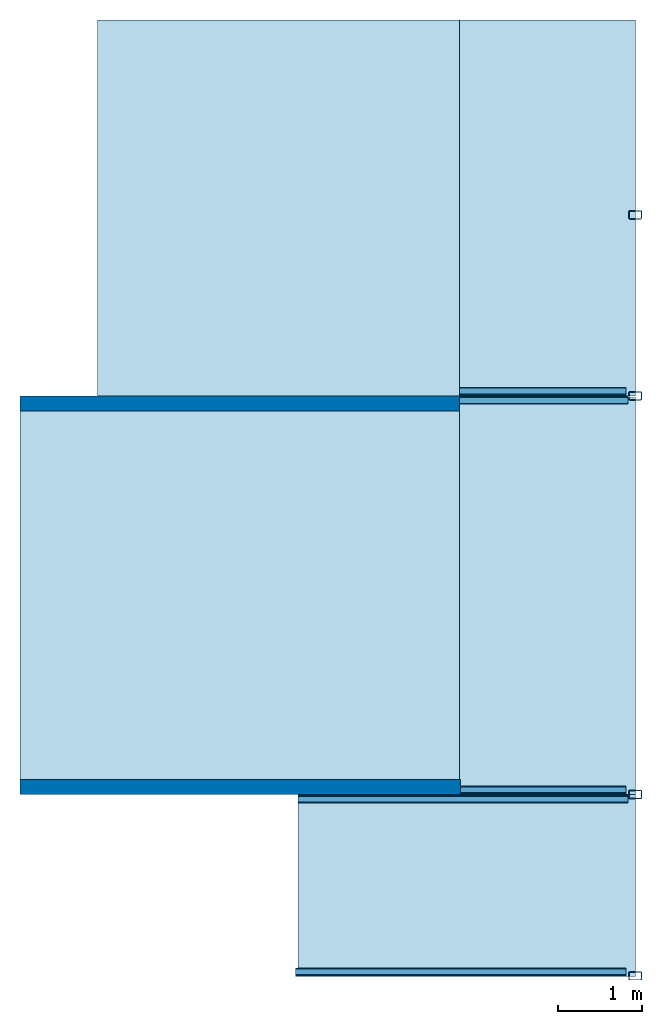
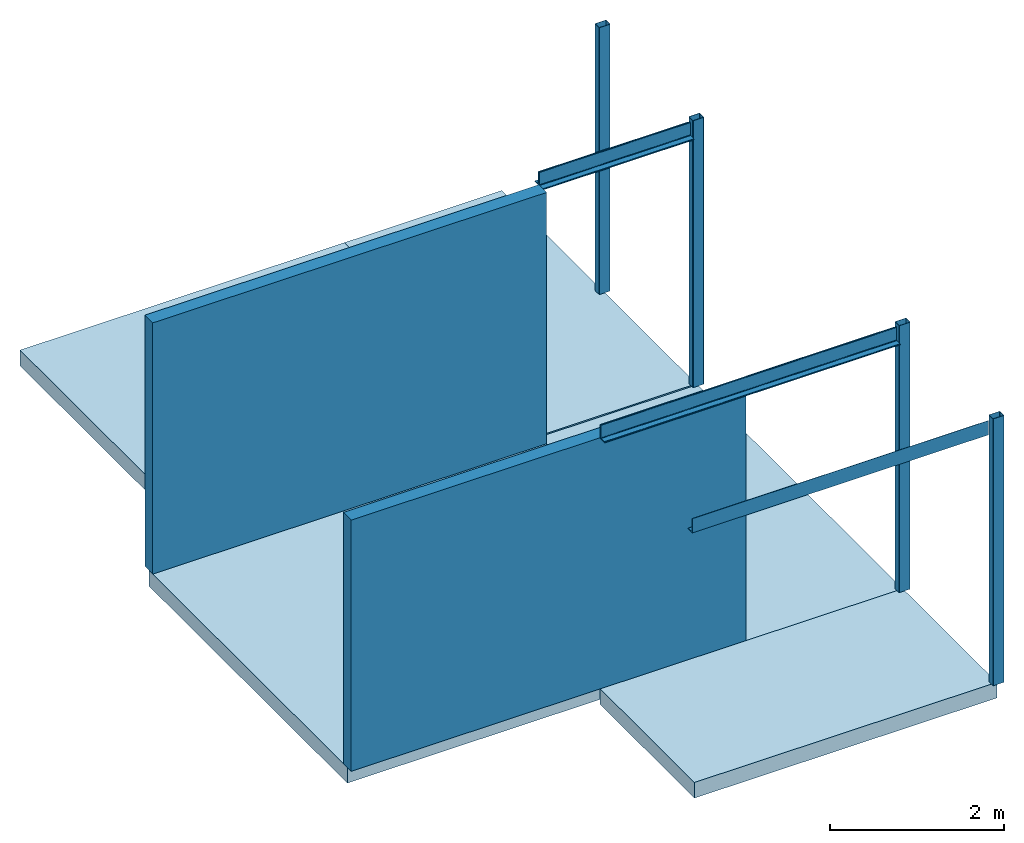
# One storey: 5 beams, 5 slabs, 4 columns, 2 walls.
"""IFC2X3 building model written with IfcOpenShell, lengths in millimetres."""

from ifc_helpers import new_model, entity, si_unit, converted_unit, frame, frame_2d, origin, place, context, project, spatial, polyline, circle_curve, parameter, trimmed, segment, composite_curve, rectangle, outline, extrude, clip, bounded_halfspace, source, transform, mapped, material, layer, layer_set, layer_usage, type_object, type_shapes, element, save


model = new_model("IFC2X3")

# Units and contexts
model_context = context("Model", 3, precision=1e-06, world=origin())
plan_context = context("Plan", 3, precision=1e-06, world=origin())
ifc_project = project(units=[si_unit("LENGTHUNIT", "METRE", prefix="MILLI"), si_unit("AREAUNIT", "SQUARE_METRE", prefix="MILLI"), si_unit("VOLUMEUNIT", "CUBIC_METRE", prefix="MILLI"), converted_unit("PLANEANGLEUNIT", "DEGREE", entity("IfcRatioMeasure", 0.01745329251994328), si_unit("PLANEANGLEUNIT", "RADIAN"), dimensions=[0, 0, 0, 0, 0, 0, 0]), si_unit("TIMEUNIT", "SECOND")], contexts=[model_context, plan_context])

# Site, building, storey
site_placement = place(None, origin())
site = spatial("IfcSite", under=ifc_project, at=site_placement, CompositionType="ELEMENT")
building_placement = place(None, origin())
building = spatial("IfcBuilding", under=site, at=building_placement, CompositionType="ELEMENT")
storey_placement = place(building_placement, frame((0.0, 0.0, 3750.0)))
storey = spatial("IfcBuildingStorey", under=building, at=storey_placement, Name="Level 2", CompositionType="ELEMENT", Elevation=3750.000000000001)

# Columns
ifc_material_1 = material(Name="Metal - Steel - 345 MPa")
column_type = type_object("IfcColumnType", Name="150x100x5", PredefinedType="COLUMN")
shared_shape = source(origin(), model_context, "Body", "SweptSolid", [
    extrude(outline(composite_curve([segment(polyline([(-40.0, -75.0), (40.0, -75.0)]), True, "CONTINUOUS"), segment(trimmed(circle_curve(frame_2d((40.0, -65.0), x_axis=(-1.0, 0.0)), 9.999999999997998), [parameter(90.00000000000009)], [parameter(180.0000000000002)], True, "PARAMETER"), True, "CONTINUOUS"), segment(polyline([(50.0, -65.0), (50.0, 65.0)]), True, "CONTINUOUS"), segment(trimmed(circle_curve(frame_2d((40.0, 65.0), x_axis=(-1.0, 0.0)), 9.99999999999999), [parameter(179.9999999999999)], [parameter(269.9999999999997)], True, "PARAMETER"), True, "CONTINUOUS"), segment(polyline([(40.0, 75.0), (-40.0, 75.0)]), True, "CONTINUOUS"), segment(trimmed(circle_curve(frame_2d((-40.0, 65.0), x_axis=(-1.0, 0.0)), 10.00000000000288), [parameter(269.9999999999995)], [parameter(359.9999999999996)], True, "PARAMETER"), True, "CONTINUOUS"), segment(polyline([(-50.0, 65.0), (-50.0, -65.0)]), True, "CONTINUOUS"), segment(trimmed(circle_curve(frame_2d((-40.0, -65.0), x_axis=(-1.0, 0.0)), 9.999999999996726), [parameter(359.9999999999996)], [parameter(89.99999999999963)], True, "PARAMETER"), True, "CONTINUOUS")], self_intersect=False), holes=[composite_curve([segment(trimmed(circle_curve(frame_2d((-40.0, -65.0), x_axis=(-1.0, 0.0)), 4.999999999996471), [parameter(0.0)], [parameter(89.99999999999999)], True, "PARAMETER"), False, "CONTINUOUS"), segment(polyline([(-45.0, -65.0), (-45.0, 65.0)]), True, "CONTINUOUS"), segment(trimmed(circle_curve(frame_2d((-40.0, 65.0), x_axis=(-1.0, 0.0)), 4.999999999998176), [parameter(270.0)], [parameter(359.9999999999999)], True, "PARAMETER"), False, "CONTINUOUS"), segment(polyline([(-40.0, 70.0), (40.0, 70.0)]), True, "CONTINUOUS"), segment(trimmed(circle_curve(frame_2d((40.0, 65.0), x_axis=(-1.0, 0.0)), 5.000000000001551), [parameter(180.0000000000001)], [parameter(270.0)], True, "PARAMETER"), False, "CONTINUOUS"), segment(polyline([(45.0, 65.0), (45.0, -65.0)]), True, "CONTINUOUS"), segment(trimmed(circle_curve(frame_2d((40.0, -65.0), x_axis=(-1.0, 0.0)), 5.000000000000011), [parameter(90.0000000000005)], [parameter(179.9999999999998)], True, "PARAMETER"), False, "CONTINUOUS"), segment(polyline([(40.0, -70.0), (-40.0, -70.0)]), True, "CONTINUOUS")], self_intersect=False)]), frame((0.0, 0.0, 3750.0), z_axis=(0.0, 0.0, 1.0), x_axis=(-1.0, 0.0, 0.0)), (0.0, 0.0, 1.0), 3749.999999999999),
])
type_shapes(column_type, [shared_shape])
for number, where, z_axis, x_axis in (
    (1, (-11917.18323242557, 151.098768151623, -3750.0), (0.0, 0.0, 1.0), (0.0, 1.0, 0.0)),
    (2, (-11917.18323242557, 2311.098768151621, -3750.0), (0.0, 0.0, 1.0), (0.0, 1.0, 0.0)),
    (3, (-11917.18323242557, 7061.098768151644, -3750.0), (0.0, 0.0, 1.0), (0.0, 1.0, 0.0)),
    (4, (-11917.18323242557, 9217.072263559809, -3750.0), (0.0, 0.0, 1.0), (0.0, 1.0, 0.0)),
):
    element("IfcColumn", number, at=place(storey_placement, frame(where, z_axis=z_axis, x_axis=x_axis)), inside=storey, type_object=column_type, material=ifc_material_1, ObjectType="150x100x5", context=model_context, shape_type="MappedRepresentation", body=[
        mapped(shared_shape, transform((0.0, 0.0, 0.0), scale=1.0)),
    ])

# Beams
beam_1_placement = place(storey_placement, frame((-12017.18323242538, 7061.098768151644, 3750.0), z_axis=(0.0, 0.0, 1.0), x_axis=(0.0, 1.0, 0.0)))
element("IfcBeam", 5, at=beam_1_placement, inside=storey, material=ifc_material_1, ObjectType="L-Angles:CAI200x100x14", context=model_context, shape_type="SweptSolid", body=[
    extrude(outline(composite_curve([segment(polyline([(-34.57142857142937, -63.14285714285688), (65.42857142857281, -63.14285714285688)]), True, "CONTINUOUS"), segment(trimmed(circle_curve(frame_2d((51.42857142857381, -63.14285714285796), x_axis=(1.0, 0.0)), 14.0), [parameter(1.017777498068326e-13)], [parameter(90.00000000000009)], True, "PARAMETER"), True, "CONTINUOUS"), segment(polyline([(51.42857142857381, -49.14285714285788), (-6.571428571429244, -49.14285714285788)]), True, "CONTINUOUS"), segment(trimmed(circle_curve(frame_2d((-6.571428571428161, -35.14285714285782), x_axis=(1.0, 0.0)), 14.0), [parameter(180.0000000000001)], [parameter(269.9999999999999)], True, "PARAMETER"), False, "CONTINUOUS"), segment(polyline([(-20.57142857142823, -35.14285714285782), (-20.57142857142823, 122.8571428571431)]), True, "CONTINUOUS"), segment(trimmed(circle_curve(frame_2d((-34.57142857142829, 122.8571428571431), x_axis=(1.0, 0.0)), 14.0), [parameter(0.0)], [parameter(90.00000000000024)], True, "PARAMETER"), True, "CONTINUOUS"), segment(polyline([(-34.57142857142829, 136.8571428571432), (-34.57142857142937, -63.14285714285688)]), True, "CONTINUOUS")], self_intersect=False)), frame((34.57142857142829, 1994.442034597584, -170.8571428571376), z_axis=(0.0, -1.0, 0.0), x_axis=(1.0, 0.0, 0.0)), (0.0, 0.0, 1.0), 1981.742033987986),
])
beam_2_placement = place(storey_placement, frame((-14011.62526702297, 7061.098768151647, 3750.0), z_axis=(0.0, 0.0, 1.0), x_axis=(0.0, -1.0, 0.0)))
element("IfcBeam", 6, at=beam_2_placement, inside=storey, material=ifc_material_1, ObjectType="L-Angles:CAI200x100x14", context=model_context, shape_type="SweptSolid", body=[
    extrude(outline(composite_curve([segment(polyline([(-63.14285714285488, -34.57142857142903), (136.8571428571451, -34.57142857142903)]), True, "CONTINUOUS"), segment(trimmed(circle_curve(frame_2d((122.8571428571451, -34.57142857142896), x_axis=(0.0, 1.0)), 14.0), [parameter(269.9999999999998)], [parameter(0.0)], True, "PARAMETER"), True, "CONTINUOUS"), segment(polyline([(122.8571428571452, -20.57142857142889), (-35.14285714285575, -20.57142857142804)]), True, "CONTINUOUS"), segment(trimmed(circle_curve(frame_2d((-35.14285714285567, -6.571428571427971), x_axis=(0.0, 1.0)), 14.0), [parameter(90.00000000000009)], [parameter(179.9999999999999)], True, "PARAMETER"), False, "CONTINUOUS"), segment(polyline([(-49.14285714285573, -6.571428571428978), (-49.14285714285541, 51.42857142857407)]), True, "CONTINUOUS"), segment(trimmed(circle_curve(frame_2d((-63.1428571428555, 51.42857142857415), x_axis=(0.0, 1.0)), 14.0), [parameter(269.9999999999999)], [parameter(359.9999999999999)], True, "PARAMETER"), True, "CONTINUOUS"), segment(polyline([(-63.14285714285434, 65.42857142857315), (-63.14285714285488, -34.57142857142903)]), True, "CONTINUOUS")], self_intersect=False)), frame((34.57142857142829, 0.0, -170.8571428571398), z_axis=(0.0, 1.0, 0.0), x_axis=(0.0, 0.0, 1.0)), (0.0, 0.0, 1.0), 2006.742034597402),
])
beam_3_placement = place(storey_placement, frame((-12017.18323242539, 2311.098768151621, 3750.0), z_axis=(0.0, 0.0, 1.0), x_axis=(0.0, 1.0, 0.0)))
element("IfcBeam", 7, at=beam_3_placement, inside=storey, material=ifc_material_1, ObjectType="L-Angles:CAI200x100x14", context=model_context, shape_type="SweptSolid", body=[
    extrude(outline(composite_curve([segment(polyline([(-34.5714285714291, -63.14285714285688), (65.42857142857306, -63.14285714285688)]), True, "CONTINUOUS"), segment(trimmed(circle_curve(frame_2d((51.428571428573, -63.14285714285796), x_axis=(0.0, 1.0)), 14.0), [parameter(269.9999999999999)], [parameter(359.9999999999999)], True, "PARAMETER"), True, "CONTINUOUS"), segment(polyline([(51.428571428573, -49.14285714285788), (-6.571428571428971, -49.14285714285788)]), True, "CONTINUOUS"), segment(trimmed(circle_curve(frame_2d((-6.571428571428971, -35.14285714285782), x_axis=(-1.0, 0.0)), 14.0), [parameter(3.562221243239142e-13)], [parameter(90.00000000000009)], True, "PARAMETER"), False, "CONTINUOUS"), segment(polyline([(-20.57142857142904, -35.14285714285782), (-20.5714285714285, 122.8571428571431)]), True, "CONTINUOUS"), segment(trimmed(circle_curve(frame_2d((-34.57142857142856, 122.8571428571431), x_axis=(0.0, 1.0)), 14.0), [parameter(269.9999999999999)], [parameter(1.52666624710249e-13)], True, "PARAMETER"), True, "CONTINUOUS"), segment(polyline([(-34.57142857142856, 136.8571428571432), (-34.5714285714291, -63.14285714285688)]), True, "CONTINUOUS")], self_intersect=False)), frame((34.57142857142883, 1980.0, -170.8571428571376), z_axis=(0.0, -1.0, 0.0), x_axis=(1.0, 0.0, 0.0)), (0.0, 0.0, 1.0), 1967.299999390401),
])
beam_4_placement = place(storey_placement, frame((-14011.62526702298, 2311.098768151623, 3750.0), z_axis=(0.0, 0.0, 1.0), x_axis=(0.0, -1.0, 0.0)))
element("IfcBeam", 8, at=beam_4_placement, inside=storey, material=ifc_material_1, ObjectType="L-Angles:CAI200x100x14", context=model_context, shape_type="SweptSolid", body=[
    extrude(outline(composite_curve([segment(polyline([(-63.14285714285479, -34.57142857142947), (136.8571428571453, -34.57142857142947)]), True, "CONTINUOUS"), segment(trimmed(circle_curve(frame_2d((122.8571428571452, -34.57142857142944), x_axis=(1.0, 0.0)), 14.0), [parameter(359.9999999999998)], [parameter(90.00000000000009)], True, "PARAMETER"), True, "CONTINUOUS"), segment(polyline([(122.8571428571452, -20.57142857142937), (-35.14285714285569, -20.57142857142948)]), True, "CONTINUOUS"), segment(trimmed(circle_curve(frame_2d((-35.14285714285565, -6.571428571429416), x_axis=(0.0, -1.0)), 14.0), [parameter(269.9999999999999)], [parameter(359.9999999999997)], True, "PARAMETER"), False, "CONTINUOUS"), segment(polyline([(-49.14285714285571, -6.571428571429378), (-49.14285714285555, 51.4285714285726)]), True, "CONTINUOUS"), segment(trimmed(circle_curve(frame_2d((-63.14285714285563, 51.42857142857263), x_axis=(1.0, 0.0)), 14.0), [parameter(1.017777498068326e-13)], [parameter(90.00000000000009)], True, "PARAMETER"), True, "CONTINUOUS"), segment(polyline([(-63.14285714285452, 65.4285714285727), (-63.14285714285479, -34.57142857142947)]), True, "CONTINUOUS")], self_intersect=False)), frame((34.5714285714291, -1925.557965402417, -170.8571428571398), z_axis=(0.0, 1.0, 0.0), x_axis=(0.0, 0.0, 1.0)), (0.0, 0.0, 1.0), 3932.299999999817),
])
beam_5_placement = place(storey_placement, frame((-12017.1832324254, 142.336632009615, 3750.0), z_axis=(0.0, 0.0, 1.0), x_axis=(0.0, 1.0, 0.0)))
element("IfcBeam", 9, at=beam_5_placement, inside=storey, material=ifc_material_1, ObjectType="L-Angles:CAI200x100x14", context=model_context, shape_type="SweptSolid", body=[
    extrude(outline(composite_curve([segment(polyline([(-34.57142857142949, -63.14285714285688), (65.4285714285727, -63.14285714285688)]), True, "CONTINUOUS"), segment(trimmed(circle_curve(frame_2d((51.42857142857273, -63.14285714285796), x_axis=(1.0, 0.0)), 14.0), [parameter(1.017777498068326e-13)], [parameter(90.00000000000009)], True, "PARAMETER"), True, "CONTINUOUS"), segment(polyline([(51.4285714285728, -49.14285714285788), (-6.571428571429273, -49.14285714285788)]), True, "CONTINUOUS"), segment(trimmed(circle_curve(frame_2d((-6.571428571429241, -35.14285714285782), x_axis=(1.0, 0.0)), 14.0), [parameter(180.0000000000001)], [parameter(269.9999999999999)], True, "PARAMETER"), False, "CONTINUOUS"), segment(polyline([(-20.57142857142927, -35.14285714285782), (-20.57142857142873, 122.8571428571431)]), True, "CONTINUOUS"), segment(trimmed(circle_curve(frame_2d((-34.57142857142875, 122.8571428571431), x_axis=(1.0, 0.0)), 14.0), [parameter(0.0)], [parameter(90.00000000000024)], True, "PARAMETER"), True, "CONTINUOUS"), segment(polyline([(-34.57142857142885, 136.8571428571432), (-34.57142857142949, -63.14285714285688)]), True, "CONTINUOUS")], self_intersect=False)), frame((34.57142857142893, 3947.2999993904, -170.8571428571376), z_axis=(0.0, -1.0, 0.0), x_axis=(1.0, 0.0, 0.0)), (0.0, 0.0, 1.0), 3934.5999987808),
])

# Slabs
ifc_material_2 = material(Name="Concrete - Cast In Situ")
ifc_layer_1 = layer(ifc_material_2, 220.0)
ifc_layer_set_1 = layer_set([ifc_layer_1], Name="Floor:Insitu Concrete 220mm")
ifc_layer_usage_1 = layer_usage(ifc_layer_set_1, "AXIS3", "POSITIVE", 0.0)
slab_1_placement = place(storey_placement, frame((-19247.18401022489, 2401.09876815164, -220.0)))
element("IfcSlab", 10, at=slab_1_placement, inside=storey, material=ifc_layer_usage_1, Name="Floor:Insitu Concrete 220mm", ObjectType="Floor:Insitu Concrete 220mm", PredefinedType="FLOOR", context=model_context, shape_type="SweptSolid", body=[
    extrude(rectangle(XDim=4570.000000000006, YDim=5250.000777799518, at=frame_2d((16622.18362132513, 4686.098768151644), x_axis=(0.0, -1.0))), frame((19247.18401022489, -2401.09876815164, 220.0), z_axis=(0.0, 0.0, -1.0), x_axis=(-1.0, 0.0, 0.0)), (0.0, 0.0, 1.0), 220.0),
])
ifc_layer_usage_2 = layer_usage(ifc_layer_set_1, "AXIS3", "POSITIVE", 0.0)
slab_2_placement = place(storey_placement, frame((-18322.18323242538, 6971.098768151646, -220.0)))
element("IfcSlab", 11, at=slab_2_placement, inside=storey, material=ifc_layer_usage_2, Name="Floor:Insitu Concrete 220mm", ObjectType="Floor:Insitu Concrete 220mm", PredefinedType="FLOOR", context=model_context, shape_type="SweptSolid", body=[
    extrude(rectangle(XDim=4567.302251788157, YDim=4310.557965402411, at=frame_2d((16166.90424972418, 9254.749894045724), x_axis=(0.0, -1.0))), frame((18322.18323242538, -6971.098768151646, 220.0), z_axis=(0.0, 0.0, -1.0), x_axis=(-1.0, 0.0, 0.0)), (0.0, 0.0, 1.0), 220.0),
])
ifc_layer_usage_3 = layer_usage(ifc_layer_set_1, "AXIS3", "POSITIVE", 0.0)
slab_3_placement = place(storey_placement, frame((-14011.62526702297, 7061.098768151647, -220.0)))
element("IfcSlab", 12, at=slab_3_placement, inside=storey, material=ifc_layer_usage_3, Name="Floor:Insitu Concrete 220mm", ObjectType="Floor:Insitu Concrete 220mm", PredefinedType="FLOOR", context=model_context, shape_type="SweptSolid", body=[
    extrude(rectangle(XDim=4477.302251788156, YDim=2094.442034597587, at=frame_2d((12964.40424972418, 9299.749894045726), x_axis=(0.0, -1.0))), frame((14011.62526702297, -7061.098768151647, 220.0), z_axis=(0.0, 0.0, -1.0), x_axis=(-1.0, 0.0, 0.0)), (0.0, 0.0, 1.0), 220.0),
])
ifc_layer_usage_4 = layer_usage(ifc_layer_set_1, "AXIS3", "POSITIVE", 0.0)
slab_4_placement = place(storey_placement, frame((-15937.18323242539, 142.3366320096107, -220.0)))
element("IfcSlab", 13, at=slab_4_placement, inside=storey, material=ifc_layer_usage_4, Name="Floor:Insitu Concrete 220mm", ObjectType="Floor:Insitu Concrete 220mm", PredefinedType="FLOOR", context=model_context, shape_type="SweptSolid", body=[
    extrude(rectangle(XDim=2168.762136142018, YDim=4019.999999999827, at=frame_2d((13927.18323242548, 1226.71770008062), x_axis=(0.0, -1.0))), frame((15937.18323242539, -142.3366320096107, 220.0), z_axis=(0.0, 0.0, -1.0), x_axis=(-1.0, 0.0, 0.0)), (0.0, 0.0, 1.0), 220.0),
])
ifc_layer_usage_5 = layer_usage(ifc_layer_set_1, "AXIS3", "POSITIVE", 0.0)
slab_5_placement = place(storey_placement, frame((-14011.62526702297, 2311.098768151617, -220.0)))
element("IfcSlab", 14, at=slab_5_placement, inside=storey, material=ifc_layer_usage_5, Name="Floor:Insitu Concrete 220mm", ObjectType="Floor:Insitu Concrete 220mm", PredefinedType="FLOOR", context=model_context, shape_type="SweptSolid", body=[
    extrude(rectangle(XDim=4728.20000000003, YDim=2094.442034597589, at=frame_2d((12964.40424972418, 4675.198768151632), x_axis=(0.0, -1.0))), frame((14011.62526702297, -2311.098768151617, 220.0), z_axis=(0.0, 0.0, -1.0), x_axis=(-1.0, 0.0, 0.0)), (0.0, 0.0, 1.0), 220.0),
])

# Walls
ifc_material_3 = material(Name="Default Wall")
ifc_layer_2 = layer(ifc_material_3, 180.0)
ifc_layer_set_2 = layer_set([ifc_layer_2], Name="Basic Wall:Generic - 180mm")
ifc_layer_usage_6 = layer_usage(ifc_layer_set_2, "AXIS2", "POSITIVE", -90.0)
wall_1_placement = place(storey_placement, frame((-19247.18401022489, 6971.098768151646, 0.0)))
element("IfcWallStandardCase", 15, at=wall_1_placement, inside=storey, material=ifc_layer_usage_6, Name="Basic Wall:Generic - 180mm", ObjectType="Basic Wall:Generic - 180mm", context=model_context, shape_type="Clipping", body=[
    clip(extrude(rectangle(XDim=5235.558743201926, YDim=180.0000000000002, at=frame_2d((2617.779371600963, 0.0), x_axis=(-1.0, 0.0))), origin(), (0.0, 0.0, 1.0), 3750.000000000001), bounded_halfspace(frame((0.0, -90.0, 3530.0), z_axis=(0.0, 0.0, 1.0), x_axis=(0.0, 1.0, 0.0)), False, frame((0.0, -90.0, 3530.0)), polyline([(0.0, 0.0), (5235.558743201926, 0.0), (5235.558743201926, 90.0), (5235.558743201925, 180.0), (0.0, 180.0), (0.0, 90.0), (0.0, 0.0)]))),
])
ifc_layer_usage_7 = layer_usage(ifc_layer_set_2, "AXIS2", "POSITIVE", -90.0)
wall_2_placement = place(storey_placement, frame((-13997.18323242538, 2401.098768151623, 0.0), z_axis=(0.0, 0.0, 1.0), x_axis=(-1.0, 0.0, 0.0)))
element("IfcWallStandardCase", 16, at=wall_2_placement, inside=storey, material=ifc_layer_usage_7, Name="Basic Wall:Generic - 180mm", ObjectType="Basic Wall:Generic - 180mm", context=model_context, shape_type="Clipping", body=[
    clip(clip(clip(extrude(rectangle(XDim=5250.000777799519, YDim=179.9999999999997, at=frame_2d((2625.000388899759, 0.0), x_axis=(-1.0, 0.0))), origin(), (0.0, 0.0, 1.0), 3750.000000000001), bounded_halfspace(frame((0.0, -90.0, 3530.0), z_axis=(0.0, 0.0, -1.0), x_axis=(0.0, 1.0, 0.0)), True, frame((0.0, -90.0, 3530.0)), polyline([(0.0, 0.0), (5250.000777799519, 0.0), (5250.000777799519, 90.0), (0.0, 90.0), (0.0, 0.0)]))), bounded_halfspace(frame((0.0, -90.0, 3530.0), z_axis=(0.0, 0.0, -1.0), x_axis=(0.0, 1.0, 0.0)), True, frame((0.0, -90.0, 3530.0)), polyline([(0.0, 0.0), (5250.000777799519, 0.0), (5250.000777799519, 90.0), (0.0, 90.0), (0.0, 0.0)]))), bounded_halfspace(frame((5250.000777799518, 0.0, 3530.0), z_axis=(0.0, 0.0, 1.0), x_axis=(0.0, 1.0, 0.0)), False, frame((5250.000777799518, 0.0, 3530.0)), polyline([(0.0, 0.0), (0.0, 90.0), (-5250.000777799519, 90.0), (-5250.000777799519, 0.0), (0.0, 0.0)]))),
])

save(model, "model.ifc")
